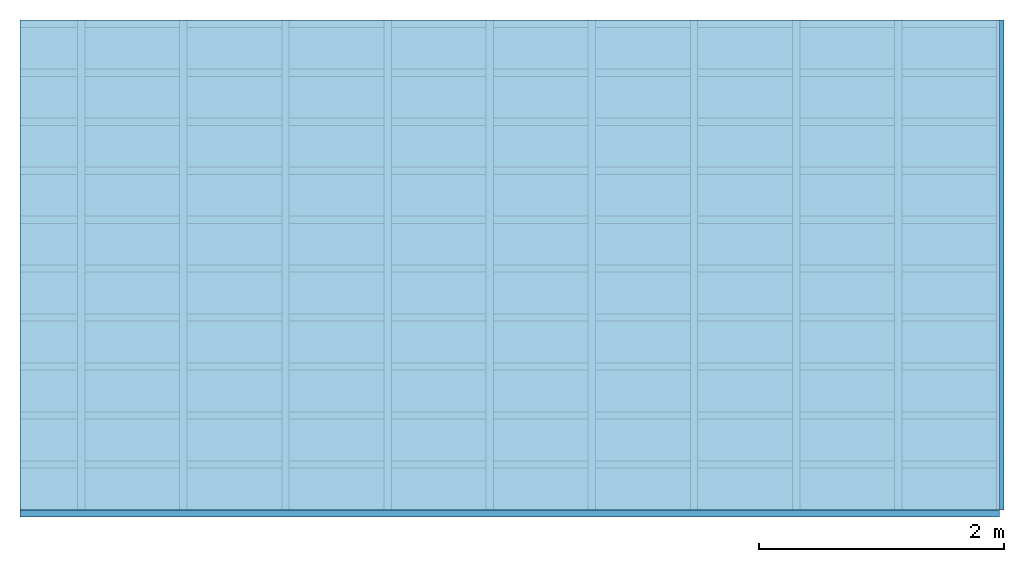
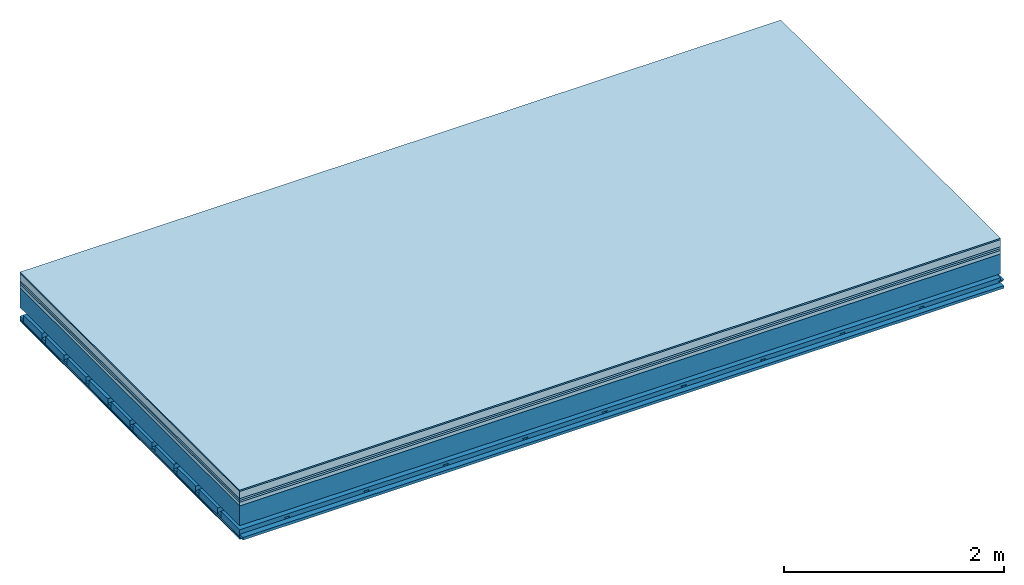
# One storey: 8 plates, 4 members, 1 element without a shape of its own.
"""IFC4 building model written with IfcOpenShell, lengths in metres."""

import ifcopenshell
import ifcopenshell.guid

model = None  # the IFC model being written
_history = None  # IfcOwnerHistory: only IFC2X3 demands one
_inside = {}  # id of a spatial element -> (the spatial element, [elements in it])
_under = {}  # id of a project, library or spatial element -> (it, [spatial elements below it])
_declared = {}  # id of a project -> (the project, [libraries it declares])
_typed = {}  # id of a type object -> (the type object, [elements of that type])
_made_of = {}  # id of a material, layer set ... -> (it, [elements and type objects made of it])


def new_model(schema):
    """Start an empty IFC model of exactly this schema.

    Asked for "IFC4X3", IfcOpenShell would pick the latest addendum, in which some entities
    have other attributes; the version numbers below select the first issue.
    IFC2X3 requires an IfcOwnerHistory on every rooted entity: one is made here for all.
    """
    global model, _history
    if schema == "IFC4X3":
        model = ifcopenshell.file(schema_version=(4, 3, 0, 0))
    else:
        model = ifcopenshell.file(schema=schema)
    _inside.clear()
    _under.clear()
    _declared.clear()
    _typed.clear()
    _made_of.clear()
    _history = None
    if model.schema == "IFC2X3":
        org = make("IfcOrganization", Name="unknown")
        user = make(
            "IfcPersonAndOrganization",
            ThePerson=make("IfcPerson", FamilyName="unknown"),
            TheOrganization=org,
        )
        app = make(
            "IfcApplication",
            ApplicationDeveloper=org,
            Version="unknown",
            ApplicationFullName="unknown",
            ApplicationIdentifier="unknown",
        )
        _history = make(
            "IfcOwnerHistory",
            OwningUser=user,
            OwningApplication=app,
            ChangeAction="ADDED",
            CreationDate=0,
        )
    return model


def make(cls, **values):
    """One entity of the class cls with the attributes given. An attribute that is None is left unset."""
    return model.create_entity(
        cls, **{name: value for name, value in values.items() if value is not None}
    )


def rooted(cls, **values):
    """An entity with a GlobalId (a new one), such as an element, a storey or a relation."""
    return make(cls, GlobalId=ifcopenshell.guid.new(), OwnerHistory=_history, **values)


def si_unit(unit_type, name, prefix=None):
    """IfcSIUnit, for example si_unit("LENGTHUNIT", "METRE", prefix="MILLI")."""
    return make("IfcSIUnit", UnitType=unit_type, Prefix=prefix, Name=name)


def derived_unit(unit_type, elements):
    """IfcDerivedUnit: a product of units, each with its exponent."""
    return make(
        "IfcDerivedUnit",
        Elements=[
            make("IfcDerivedUnitElement", Unit=unit, Exponent=power)
            for unit, power in elements
        ],
        UnitType=unit_type,
    )


def assignment(units):
    """IfcUnitAssignment: the units of a project."""
    return None if units is None else make("IfcUnitAssignment", Units=units)


def point(xyz):
    """IfcCartesianPoint."""
    return None if xyz is None else make("IfcCartesianPoint", Coordinates=xyz)


def direction(xyz):
    """IfcDirection."""
    return None if xyz is None else make("IfcDirection", DirectionRatios=xyz)


def frame(location, z_axis=None, x_axis=None):
    """IfcAxis2Placement3D, a coordinate frame: its origin and axes. An axis left out is left unset."""
    return make(
        "IfcAxis2Placement3D",
        Location=point(location),
        Axis=direction(z_axis),
        RefDirection=direction(x_axis),
    )


def frame_2d(location, x_axis=None):
    """IfcAxis2Placement2D, a coordinate frame in the plane: its origin and x axis."""
    return make(
        "IfcAxis2Placement2D", Location=point(location), RefDirection=direction(x_axis)
    )


def origin():
    """The frame at (0, 0, 0) with its axes left unset."""
    return frame((0.0, 0.0, 0.0))


def origin_with_axes():
    """The frame at (0, 0, 0) with the z axis (0, 0, 1) and the x axis (1, 0, 0) written out."""
    return frame((0.0, 0.0, 0.0), z_axis=(0.0, 0.0, 1.0), x_axis=(1.0, 0.0, 0.0))


def place(relative_to, where):
    """IfcLocalPlacement: puts the frame where relative to a parent placement (None: the world)."""
    return make(
        "IfcLocalPlacement", PlacementRelTo=relative_to, RelativePlacement=where
    )


def context(
    kind, dimensions, precision=None, world=None, true_north=None, identifier=None
):
    """IfcGeometricRepresentationContext, for example the 3D "Model" context."""
    return make(
        "IfcGeometricRepresentationContext",
        ContextIdentifier=identifier,
        ContextType=kind,
        CoordinateSpaceDimension=dimensions,
        Precision=precision,
        WorldCoordinateSystem=world,
        TrueNorth=true_north,
    )


def project(units=None, contexts=None):
    """IfcProject with its units and contexts."""
    return rooted(
        "IfcProject",
        Name="project",
        RepresentationContexts=contexts,
        UnitsInContext=assignment(units),
    )


def spatial(cls, under=None, at=None, **own):
    """A site, building, storey or space (cls), placed at a placement, below another one or the project."""
    s = rooted(cls, ObjectPlacement=at, **own)
    if under is not None:
        _under.setdefault(under.id(), (under, []))[1].append(s)
    return s


def polyline(points):
    """IfcPolyline through the points."""
    return make("IfcPolyline", Points=[point(p) for p in points])


def profile(cls, at=None, kind="AREA", **sizes):
    """A parametric profile (cls). Its sizes go by their IFC names, for example OverallWidth=200.0."""
    return make(cls, ProfileType=kind, Position=at, **sizes)


def rectangle(**sizes):
    """IfcRectangleProfileDef."""
    return profile("IfcRectangleProfileDef", **sizes)


def outline(outer, holes=None, kind="AREA"):
    """IfcArbitraryClosedProfileDef: a profile drawn as a closed curve; with holes, ...WithVoids."""
    if holes is None:
        return make("IfcArbitraryClosedProfileDef", ProfileType=kind, OuterCurve=outer)
    return make(
        "IfcArbitraryProfileDefWithVoids",
        ProfileType=kind,
        OuterCurve=outer,
        InnerCurves=holes,
    )


def extrude(swept, where, along, depth):
    """IfcExtrudedAreaSolid: the profile swept, set in the frame where, extruded along a direction by depth."""
    return make(
        "IfcExtrudedAreaSolid",
        SweptArea=swept,
        Position=where,
        ExtrudedDirection=direction(along),
        Depth=depth,
    )


def shape(context_of_items, identifier, shape_type, items):
    """IfcShapeRepresentation: the items that make up one representation, for example the "Body"."""
    return make(
        "IfcShapeRepresentation",
        ContextOfItems=context_of_items,
        RepresentationIdentifier=identifier,
        RepresentationType=shape_type,
        Items=items,
    )


def material(Name=None, Category=None):
    """IfcMaterial."""
    return make("IfcMaterial", Name=Name, Category=Category)


def layer(
    of_material, thickness, ventilated=None, Name=None, Category=None, Priority=None
):
    """IfcMaterialLayer: one layer of a wall or slab, of a material (None: an air gap)."""
    return make(
        "IfcMaterialLayer",
        Material=of_material,
        LayerThickness=thickness,
        IsVentilated=ventilated,
        Name=Name,
        Category=Category,
        Priority=Priority,
    )


def layer_set(layers, Name=None):
    """IfcMaterialLayerSet."""
    return make("IfcMaterialLayerSet", MaterialLayers=layers, LayerSetName=Name)


def made_of(thing, what):
    """Note that an element or type object is made of a material, layer set ...; save() writes the relation."""
    if what is not None:
        _made_of.setdefault(what.id(), (what, []))[1].append(thing)
    return thing


def type_object(cls, material=None, **own):
    """A type object (cls), such as IfcWallType, which elements share."""
    return made_of(rooted(cls, **own), material)


def element(
    cls,
    number,
    at=None,
    inside=None,
    cuts=None,
    type_object=None,
    material=None,
    context=None,
    identifier="Body",
    shape_type=None,
    held_by="IfcProductDefinitionShape",
    body=None,
    shapes=None,
    **own,
):
    """One element of the class cls, such as IfcWall. Its Tag is "e" and its number.

    at: its placement. inside: the storey or other place that contains it. cuts: it is an
    opening in that element (IfcRelVoidsElement). A single representation is given by context,
    identifier, shape_type and body (its items); several are given by shapes. held_by: the class
    of the entity that holds the representations. save() writes the other relations.
    """
    e = rooted(cls, Tag="e%d" % number, ObjectPlacement=at, **own)
    if body is not None:
        shapes = [shape(context, identifier, shape_type, body)]
    if shapes is not None:
        e.Representation = make(held_by, Representations=shapes)
    if inside is not None:
        _inside.setdefault(inside.id(), (inside, []))[1].append(e)
    if cuts is not None:
        rooted(
            "IfcRelVoidsElement", RelatingBuildingElement=cuts, RelatedOpeningElement=e
        )
    if type_object is not None:
        _typed.setdefault(type_object.id(), (type_object, []))[1].append(e)
    return made_of(e, material)


def aggregate(whole, parts):
    """IfcRelAggregates: a whole, such as a stair, and the parts it consists of."""
    return rooted("IfcRelAggregates", RelatingObject=whole, RelatedObjects=parts)


def save(model, path):
    """Write the relations noted so far, then the file.

    IfcRelAggregates (storeys below a building ...), IfcRelContainedInSpatialStructure (elements
    in a storey), IfcRelDefinesByType, IfcRelAssociatesMaterial and IfcRelDeclares: one each for
    every whole, place, type object, material and project.
    """
    for whole, parts in _under.values():
        aggregate(whole, parts)
    for where, things in _inside.values():
        rooted(
            "IfcRelContainedInSpatialStructure",
            RelatedElements=things,
            RelatingStructure=where,
        )
    for kind, things in _typed.values():
        rooted("IfcRelDefinesByType", RelatedObjects=things, RelatingType=kind)
    for what, things in _made_of.values():
        rooted("IfcRelAssociatesMaterial", RelatedObjects=things, RelatingMaterial=what)
    for by, libraries in _declared.values():
        rooted("IfcRelDeclares", RelatingContext=by, RelatedDefinitions=libraries)
    model.write(path)


model = new_model("IFC4")

# Units and contexts
plan_context = context("Plan", 3, precision=1e-05, world=origin(), true_north=direction((0.0, 1.0)))
model_context = context("Model", 3, precision=1e-05, world=origin(), true_north=direction((0.0, 1.0)))
ifc_project = project(units=[si_unit("LENGTHUNIT", "METRE"), derived_unit("SOUNDPRESSUREUNIT", [(si_unit("PRESSUREUNIT", "PASCAL", prefix="MICRO"), 0)]), si_unit("ENERGYUNIT", "JOULE", prefix="MEGA"), si_unit("MASSUNIT", "GRAM", prefix="KILO"), derived_unit("THERMALTRANSMITTANCEUNIT", [(si_unit("POWERUNIT", "WATT"), 1), (si_unit("AREAUNIT", "SQUARE_METRE"), -1), (si_unit("THERMODYNAMICTEMPERATUREUNIT", "KELVIN"), -1)]), derived_unit("AREADENSITYUNIT", [(si_unit("MASSUNIT", "GRAM", prefix="KILO"), 1), (si_unit("AREAUNIT", "SQUARE_METRE"), -1)]), derived_unit("USERDEFINED", [(si_unit("ENERGYUNIT", "JOULE", prefix="MEGA"), 1), (si_unit("AREAUNIT", "SQUARE_METRE"), -1)])], contexts=[plan_context, model_context])

# Site, building, storey
site = spatial("IfcSite", under=ifc_project)
building_placement = place(None, origin())
building = spatial("IfcBuilding", under=site, at=building_placement)
storey_placement = place(building_placement, origin())
storey = spatial("IfcBuildingStorey", under=building, at=storey_placement)

# Slab, members, plates
ifc_material_1 = material(Category="11.013")
ifc_layer_1 = layer(ifc_material_1, 0.015, Name="Flooring")
ifc_material_2 = material(Name="Cement screed", Category="04.006")
ifc_layer_2 = layer(ifc_material_2, 0.08, Name="On-material")
ifc_material_3 = material(Name="Wood fiber generic product", Category="10.009")
ifc_layer_3 = layer(ifc_material_3, 0.02, Name="Impact sound insulation")
ifc_material_4 = material(Category="10.004")
ifc_layer_4 = layer(ifc_material_4, 0.02, Name="Additional insulation")
ifc_material_5 = material(Name="Garden plates", Category="02.007")
ifc_layer_5 = layer(ifc_material_5, 0.04, Name="on Supporting structure")
ifc_material_6 = material(Name="no composite action")
ifc_layer_6 = layer(ifc_material_6, 0.0, Name="Bond")
ifc_layer_7 = layer(None, 0.22, Name="Supporting structure")
ifc_layer_8 = layer(ifc_material_6, 0.0, Name="Bond")
ifc_layer_9 = layer(None, 0.095, Name="Coupling")
ifc_layer_10 = layer(None, 0.03, Name="Battens / profiles")
ifc_material_7 = material(Name="Plasterboard type A", Category="03.008")
ifc_layer_11 = layer(ifc_material_7, 0.0125, Name="Ceiling covering 1st layer")
ifc_layer_12 = layer(ifc_material_7, 0.0125, Name="Ceiling covering layer 2")
ifc_material_8 = material(Category="04.001")
ifc_layer_13 = layer(ifc_material_8, 0.003, Name="Surface / treatment")
ifc_layer_set = layer_set([ifc_layer_1, ifc_layer_2, ifc_layer_3, ifc_layer_4, ifc_layer_5, ifc_layer_6, ifc_layer_7, ifc_layer_8, ifc_layer_9, ifc_layer_10, ifc_layer_11, ifc_layer_12, ifc_layer_13])
slab_type = type_object("IfcSlabType", Name="A2173", PredefinedType="NOTDEFINED", material=ifc_layer_set)
slab_placement = place(None, frame((0.0, 0.0, 0.0), z_axis=(0.0, 0.0, -1.0), x_axis=(1.0, 0.0, 0.0)))
slab = element("IfcSlab", 1, at=slab_placement, inside=storey, type_object=slab_type, material=ifc_layer_set, Name="Slab #1")
ifc_material_9 = material(Name="Solid timber panel")
member_1_placement = place(slab_placement, origin())
member_1 = element("IfcMember", 2, at=member_1_placement, material=ifc_material_9, Name="Supporting structure", context=plan_context, shape_type="SweptSolid", body=[
    extrude(rectangle(XDim=1.0, YDim=0.22, at=frame_2d((0.5, 0.11), x_axis=(1.0, 0.0))), frame((0.0, 4.0, 0.175), z_axis=(0.0, -1.0, 0.0), x_axis=(1.0, 0.0, 0.0)), (0.0, 0.0, 1.0), 4.0),
    extrude(rectangle(XDim=1.0, YDim=0.22, at=frame_2d((0.5, 0.11), x_axis=(1.0, 0.0))), frame((1.0, 4.0, 0.175), z_axis=(0.0, -1.0, 0.0), x_axis=(1.0, 0.0, 0.0)), (0.0, 0.0, 1.0), 4.0),
    extrude(rectangle(XDim=1.0, YDim=0.22, at=frame_2d((0.5, 0.11), x_axis=(1.0, 0.0))), frame((2.0, 4.0, 0.175), z_axis=(0.0, -1.0, 0.0), x_axis=(1.0, 0.0, 0.0)), (0.0, 0.0, 1.0), 4.0),
    extrude(rectangle(XDim=1.0, YDim=0.22, at=frame_2d((0.5, 0.11), x_axis=(1.0, 0.0))), frame((3.0, 4.0, 0.175), z_axis=(0.0, -1.0, 0.0), x_axis=(1.0, 0.0, 0.0)), (0.0, 0.0, 1.0), 4.0),
    extrude(rectangle(XDim=1.0, YDim=0.22, at=frame_2d((0.5, 0.11), x_axis=(1.0, 0.0))), frame((4.0, 4.0, 0.175), z_axis=(0.0, -1.0, 0.0), x_axis=(1.0, 0.0, 0.0)), (0.0, 0.0, 1.0), 4.0),
    extrude(rectangle(XDim=1.0, YDim=0.22, at=frame_2d((0.5, 0.11), x_axis=(1.0, 0.0))), frame((5.0, 4.0, 0.175), z_axis=(0.0, -1.0, 0.0), x_axis=(1.0, 0.0, 0.0)), (0.0, 0.0, 1.0), 4.0),
    extrude(rectangle(XDim=1.0, YDim=0.22, at=frame_2d((0.5, 0.11), x_axis=(1.0, 0.0))), frame((6.0, 4.0, 0.175), z_axis=(0.0, -1.0, 0.0), x_axis=(1.0, 0.0, 0.0)), (0.0, 0.0, 1.0), 4.0),
    extrude(rectangle(XDim=1.0, YDim=0.22, at=frame_2d((0.5, 0.11), x_axis=(1.0, 0.0))), frame((7.0, 4.0, 0.175), z_axis=(0.0, -1.0, 0.0), x_axis=(1.0, 0.0, 0.0)), (0.0, 0.0, 1.0), 4.0),
])
ifc_material_10 = material()
member_2_placement = place(slab_placement, origin())
member_2 = element("IfcMember", 3, at=member_2_placement, material=ifc_material_10, Name="Coupling", context=plan_context, shape_type="SweptSolid", body=[
    extrude(outline(polyline([(0.0, 0.0), (0.06, 0.0), (0.04, 0.02), (0.02, 0.02), (0.0, 0.0)])), frame((0.47, 4.0, 0.47), z_axis=(0.0, -1.0, 0.0), x_axis=(1.0, 0.0, 0.0)), (0.0, 0.0, 1.0), 4.0),
    extrude(outline(polyline([(0.0, 0.0), (0.06, 0.0), (0.04, 0.02), (0.02, 0.02), (0.0, 0.0)])), frame((1.304, 4.0, 0.47), z_axis=(0.0, -1.0, 0.0), x_axis=(1.0, 0.0, 0.0)), (0.0, 0.0, 1.0), 4.0),
    extrude(outline(polyline([(0.0, 0.0), (0.06, 0.0), (0.04, 0.02), (0.02, 0.02), (0.0, 0.0)])), frame((2.138, 4.0, 0.47), z_axis=(0.0, -1.0, 0.0), x_axis=(1.0, 0.0, 0.0)), (0.0, 0.0, 1.0), 4.0),
    extrude(outline(polyline([(0.0, 0.0), (0.06, 0.0), (0.04, 0.02), (0.02, 0.02), (0.0, 0.0)])), frame((2.972, 4.0, 0.47), z_axis=(0.0, -1.0, 0.0), x_axis=(1.0, 0.0, 0.0)), (0.0, 0.0, 1.0), 4.0),
    extrude(outline(polyline([(0.0, 0.0), (0.06, 0.0), (0.04, 0.02), (0.02, 0.02), (0.0, 0.0)])), frame((3.806, 4.0, 0.47), z_axis=(0.0, -1.0, 0.0), x_axis=(1.0, 0.0, 0.0)), (0.0, 0.0, 1.0), 4.0),
    extrude(outline(polyline([(0.0, 0.0), (0.06, 0.0), (0.04, 0.02), (0.02, 0.02), (0.0, 0.0)])), frame((4.64, 4.0, 0.47), z_axis=(0.0, -1.0, 0.0), x_axis=(1.0, 0.0, 0.0)), (0.0, 0.0, 1.0), 4.0),
    extrude(outline(polyline([(0.0, 0.0), (0.06, 0.0), (0.04, 0.02), (0.02, 0.02), (0.0, 0.0)])), frame((5.474, 4.0, 0.47), z_axis=(0.0, -1.0, 0.0), x_axis=(1.0, 0.0, 0.0)), (0.0, 0.0, 1.0), 4.0),
    extrude(outline(polyline([(0.0, 0.0), (0.06, 0.0), (0.04, 0.02), (0.02, 0.02), (0.0, 0.0)])), frame((6.308, 4.0, 0.47), z_axis=(0.0, -1.0, 0.0), x_axis=(1.0, 0.0, 0.0)), (0.0, 0.0, 1.0), 4.0),
    extrude(outline(polyline([(0.0, 0.0), (0.06, 0.0), (0.04, 0.02), (0.02, 0.02), (0.0, 0.0)])), frame((7.142, 4.0, 0.47), z_axis=(0.0, -1.0, 0.0), x_axis=(1.0, 0.0, 0.0)), (0.0, 0.0, 1.0), 4.0),
    extrude(outline(polyline([(0.0, 0.0), (0.06, 0.0), (0.04, 0.02), (0.02, 0.02), (0.0, 0.0)])), frame((7.976, 4.0, 0.47), z_axis=(0.0, -1.0, 0.0), x_axis=(1.0, 0.0, 0.0)), (0.0, 0.0, 1.0), 4.0),
])
member_3_placement = place(slab_placement, origin())
member_3 = element("IfcMember", 4, at=member_3_placement, material=ifc_material_10, Name="Battens / profiles", context=plan_context, shape_type="SweptSolid", body=[
    extrude(rectangle(XDim=0.06, YDim=0.03, at=frame_2d((0.03, 0.015), x_axis=(1.0, 0.0))), frame((0.0, 0.0, 0.49), z_axis=(1.0, 0.0, 0.0), x_axis=(0.0, 1.0, 0.0)), (0.0, 0.0, 1.0), 8.0),
    extrude(rectangle(XDim=0.06, YDim=0.03, at=frame_2d((0.03, 0.015), x_axis=(1.0, 0.0))), frame((0.0, 0.4, 0.49), z_axis=(1.0, 0.0, 0.0), x_axis=(0.0, 1.0, 0.0)), (0.0, 0.0, 1.0), 8.0),
    extrude(rectangle(XDim=0.06, YDim=0.03, at=frame_2d((0.03, 0.015), x_axis=(1.0, 0.0))), frame((0.0, 0.8, 0.49), z_axis=(1.0, 0.0, 0.0), x_axis=(0.0, 1.0, 0.0)), (0.0, 0.0, 1.0), 8.0),
    extrude(rectangle(XDim=0.06, YDim=0.03, at=frame_2d((0.03, 0.015), x_axis=(1.0, 0.0))), frame((0.0, 1.2, 0.49), z_axis=(1.0, 0.0, 0.0), x_axis=(0.0, 1.0, 0.0)), (0.0, 0.0, 1.0), 8.0),
    extrude(rectangle(XDim=0.06, YDim=0.03, at=frame_2d((0.03, 0.015), x_axis=(1.0, 0.0))), frame((0.0, 1.6, 0.49), z_axis=(1.0, 0.0, 0.0), x_axis=(0.0, 1.0, 0.0)), (0.0, 0.0, 1.0), 8.0),
    extrude(rectangle(XDim=0.06, YDim=0.03, at=frame_2d((0.03, 0.015), x_axis=(1.0, 0.0))), frame((0.0, 2.0, 0.49), z_axis=(1.0, 0.0, 0.0), x_axis=(0.0, 1.0, 0.0)), (0.0, 0.0, 1.0), 8.0),
    extrude(rectangle(XDim=0.06, YDim=0.03, at=frame_2d((0.03, 0.015), x_axis=(1.0, 0.0))), frame((0.0, 2.4, 0.49), z_axis=(1.0, 0.0, 0.0), x_axis=(0.0, 1.0, 0.0)), (0.0, 0.0, 1.0), 8.0),
    extrude(rectangle(XDim=0.06, YDim=0.03, at=frame_2d((0.03, 0.015), x_axis=(1.0, 0.0))), frame((0.0, 2.8, 0.49), z_axis=(1.0, 0.0, 0.0), x_axis=(0.0, 1.0, 0.0)), (0.0, 0.0, 1.0), 8.0),
    extrude(rectangle(XDim=0.06, YDim=0.03, at=frame_2d((0.03, 0.015), x_axis=(1.0, 0.0))), frame((0.0, 3.2, 0.49), z_axis=(1.0, 0.0, 0.0), x_axis=(0.0, 1.0, 0.0)), (0.0, 0.0, 1.0), 8.0),
    extrude(rectangle(XDim=0.06, YDim=0.03, at=frame_2d((0.03, 0.015), x_axis=(1.0, 0.0))), frame((0.0, 3.6, 0.49), z_axis=(1.0, 0.0, 0.0), x_axis=(0.0, 1.0, 0.0)), (0.0, 0.0, 1.0), 8.0),
    extrude(rectangle(XDim=0.06, YDim=0.03, at=frame_2d((0.03, 0.015), x_axis=(1.0, 0.0))), frame((0.0, 4.0, 0.49), z_axis=(1.0, 0.0, 0.0), x_axis=(0.0, 1.0, 0.0)), (0.0, 0.0, 1.0), 8.0),
])
ifc_material_11 = material()
member_4_placement = place(slab_placement, origin())
member_4 = element("IfcMember", 5, at=member_4_placement, material=ifc_material_11, Name="Cavity", context=plan_context, shape_type="SweptSolid", body=[
    extrude(rectangle(XDim=0.34, YDim=0.08, at=frame_2d((0.17, 0.04), x_axis=(1.0, 0.0))), frame((0.0, 0.06, 0.44), z_axis=(1.0, 0.0, 0.0), x_axis=(0.0, 1.0, 0.0)), (0.0, 0.0, 1.0), 8.0),
    extrude(rectangle(XDim=0.34, YDim=0.08, at=frame_2d((0.17, 0.04), x_axis=(1.0, 0.0))), frame((0.0, 0.46, 0.44), z_axis=(1.0, 0.0, 0.0), x_axis=(0.0, 1.0, 0.0)), (0.0, 0.0, 1.0), 8.0),
    extrude(rectangle(XDim=0.34, YDim=0.08, at=frame_2d((0.17, 0.04), x_axis=(1.0, 0.0))), frame((0.0, 0.86, 0.44), z_axis=(1.0, 0.0, 0.0), x_axis=(0.0, 1.0, 0.0)), (0.0, 0.0, 1.0), 8.0),
    extrude(rectangle(XDim=0.34, YDim=0.08, at=frame_2d((0.17, 0.04), x_axis=(1.0, 0.0))), frame((0.0, 1.26, 0.44), z_axis=(1.0, 0.0, 0.0), x_axis=(0.0, 1.0, 0.0)), (0.0, 0.0, 1.0), 8.0),
    extrude(rectangle(XDim=0.34, YDim=0.08, at=frame_2d((0.17, 0.04), x_axis=(1.0, 0.0))), frame((0.0, 1.66, 0.44), z_axis=(1.0, 0.0, 0.0), x_axis=(0.0, 1.0, 0.0)), (0.0, 0.0, 1.0), 8.0),
    extrude(rectangle(XDim=0.34, YDim=0.08, at=frame_2d((0.17, 0.04), x_axis=(1.0, 0.0))), frame((0.0, 2.06, 0.44), z_axis=(1.0, 0.0, 0.0), x_axis=(0.0, 1.0, 0.0)), (0.0, 0.0, 1.0), 8.0),
    extrude(rectangle(XDim=0.34, YDim=0.08, at=frame_2d((0.17, 0.04), x_axis=(1.0, 0.0))), frame((0.0, 2.46, 0.44), z_axis=(1.0, 0.0, 0.0), x_axis=(0.0, 1.0, 0.0)), (0.0, 0.0, 1.0), 8.0),
    extrude(rectangle(XDim=0.34, YDim=0.08, at=frame_2d((0.17, 0.04), x_axis=(1.0, 0.0))), frame((0.0, 2.86, 0.44), z_axis=(1.0, 0.0, 0.0), x_axis=(0.0, 1.0, 0.0)), (0.0, 0.0, 1.0), 8.0),
    extrude(rectangle(XDim=0.34, YDim=0.08, at=frame_2d((0.17, 0.04), x_axis=(1.0, 0.0))), frame((0.0, 3.26, 0.44), z_axis=(1.0, 0.0, 0.0), x_axis=(0.0, 1.0, 0.0)), (0.0, 0.0, 1.0), 8.0),
    extrude(rectangle(XDim=0.34, YDim=0.08, at=frame_2d((0.17, 0.04), x_axis=(1.0, 0.0))), frame((0.0, 3.66, 0.44), z_axis=(1.0, 0.0, 0.0), x_axis=(0.0, 1.0, 0.0)), (0.0, 0.0, 1.0), 8.0),
])
plate_1_placement = place(slab_placement, origin())
plate_1 = element("IfcPlate", 6, at=plate_1_placement, material=ifc_material_1, Name="Flooring", context=plan_context, shape_type="SweptSolid", body=[
    extrude(rectangle(XDim=8.0, YDim=4.0, at=frame_2d((4.0, 2.0), x_axis=(1.0, 0.0))), origin_with_axes(), (0.0, 0.0, 1.0), 0.015),
])
plate_2_placement = place(slab_placement, origin())
plate_2 = element("IfcPlate", 7, at=plate_2_placement, material=ifc_material_2, Name="On-material", context=plan_context, shape_type="SweptSolid", body=[
    extrude(rectangle(XDim=8.0, YDim=4.0, at=frame_2d((4.0, 2.0), x_axis=(1.0, 0.0))), frame((0.0, 0.0, 0.015), z_axis=(0.0, 0.0, 1.0), x_axis=(1.0, 0.0, 0.0)), (0.0, 0.0, 1.0), 0.08),
])
plate_3_placement = place(slab_placement, origin())
plate_3 = element("IfcPlate", 8, at=plate_3_placement, material=ifc_material_3, Name="Impact sound insulation", context=plan_context, shape_type="SweptSolid", body=[
    extrude(rectangle(XDim=8.0, YDim=4.0, at=frame_2d((4.0, 2.0), x_axis=(1.0, 0.0))), frame((0.0, 0.0, 0.095), z_axis=(0.0, 0.0, 1.0), x_axis=(1.0, 0.0, 0.0)), (0.0, 0.0, 1.0), 0.02),
])
plate_4_placement = place(slab_placement, origin())
plate_4 = element("IfcPlate", 9, at=plate_4_placement, material=ifc_material_4, Name="Additional insulation", context=plan_context, shape_type="SweptSolid", body=[
    extrude(rectangle(XDim=8.0, YDim=4.0, at=frame_2d((4.0, 2.0), x_axis=(1.0, 0.0))), frame((0.0, 0.0, 0.115), z_axis=(0.0, 0.0, 1.0), x_axis=(1.0, 0.0, 0.0)), (0.0, 0.0, 1.0), 0.02),
])
plate_5_placement = place(slab_placement, origin())
plate_5 = element("IfcPlate", 10, at=plate_5_placement, material=ifc_material_5, Name="on Supporting structure", context=plan_context, shape_type="SweptSolid", body=[
    extrude(rectangle(XDim=8.0, YDim=4.0, at=frame_2d((4.0, 2.0), x_axis=(1.0, 0.0))), frame((0.0, 0.0, 0.135), z_axis=(0.0, 0.0, 1.0), x_axis=(1.0, 0.0, 0.0)), (0.0, 0.0, 1.0), 0.04),
])
plate_6_placement = place(slab_placement, origin())
plate_6 = element("IfcPlate", 11, at=plate_6_placement, material=ifc_material_7, Name="Ceiling covering 1st layer", context=plan_context, shape_type="SweptSolid", body=[
    extrude(rectangle(XDim=8.0, YDim=4.0, at=frame_2d((4.0, 2.0), x_axis=(1.0, 0.0))), frame((0.0, 0.0, 0.52), z_axis=(0.0, 0.0, 1.0), x_axis=(1.0, 0.0, 0.0)), (0.0, 0.0, 1.0), 0.0125),
])
plate_7_placement = place(slab_placement, origin())
plate_7 = element("IfcPlate", 12, at=plate_7_placement, material=ifc_material_7, Name="Ceiling covering layer 2", context=plan_context, shape_type="SweptSolid", body=[
    extrude(rectangle(XDim=8.0, YDim=4.0, at=frame_2d((4.0, 2.0), x_axis=(1.0, 0.0))), frame((0.0, 0.0, 0.5325), z_axis=(0.0, 0.0, 1.0), x_axis=(1.0, 0.0, 0.0)), (0.0, 0.0, 1.0), 0.0125),
])
plate_8_placement = place(slab_placement, origin())
plate_8 = element("IfcPlate", 13, at=plate_8_placement, material=ifc_material_8, Name="Surface / treatment", context=plan_context, shape_type="SweptSolid", body=[
    extrude(rectangle(XDim=8.0, YDim=4.0, at=frame_2d((4.0, 2.0), x_axis=(1.0, 0.0))), frame((0.0, 0.0, 0.545), z_axis=(0.0, 0.0, 1.0), x_axis=(1.0, 0.0, 0.0)), (0.0, 0.0, 1.0), 0.003),
])
aggregate(slab, [plate_1, plate_2, plate_3, plate_4, plate_5, member_1, member_2, member_3, member_4, plate_6, plate_7, plate_8])

save(model, "model.ifc")
